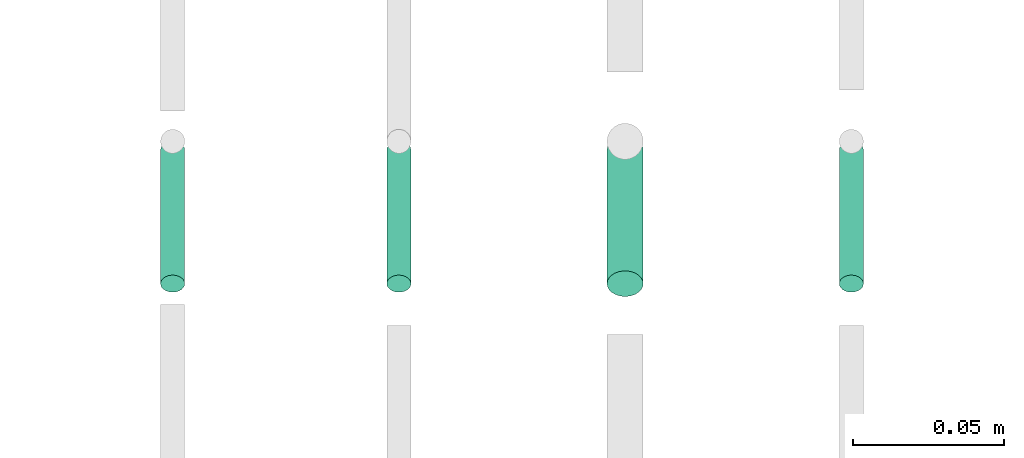
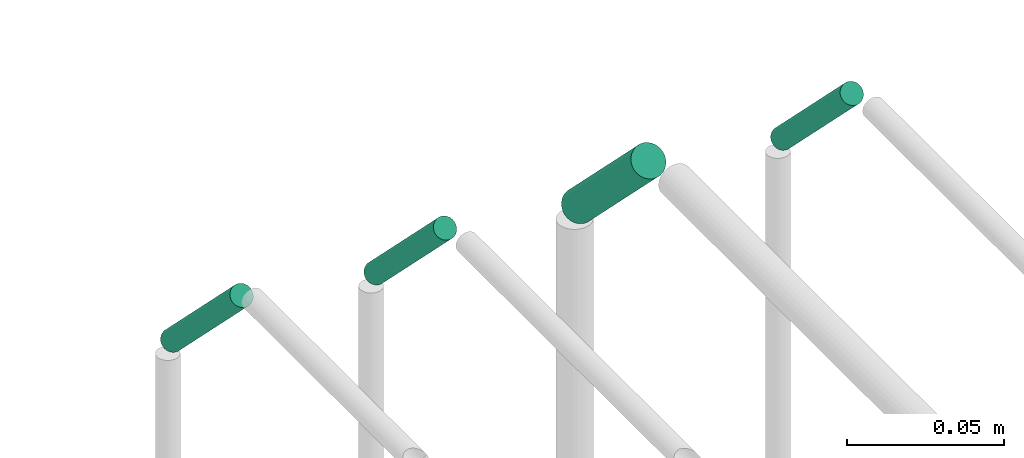
# One storey, part 268 of 331: 4 flow segments.
"""IFC2X3 building model written with IfcOpenShell, lengths in millimetres."""

from ifc_helpers import new_model, entity, si_unit, converted_unit, derived_unit, direction, frame, frame_2d, origin, place, context, subcontext, project, spatial, circle, extrude, type_object, element, save


model = new_model("IFC2X3")

# Units and contexts
model_context = context("Model", 3, precision=0.01, world=origin(), true_north=direction((6.12303176911189e-17, 1.0)))
body_context = subcontext(model_context, "Body", "Model", "MODEL_VIEW")
ifc_project = project(units=[si_unit("LENGTHUNIT", "METRE", prefix="MILLI"), si_unit("AREAUNIT", "SQUARE_METRE"), si_unit("VOLUMEUNIT", "CUBIC_METRE"), converted_unit("PLANEANGLEUNIT", "DEGREE", entity("IfcRatioMeasure", 0.0174532925199433), si_unit("PLANEANGLEUNIT", "RADIAN"), dimensions=[0, 0, 0, 0, 0, 0, 0]), si_unit("MASSUNIT", "GRAM", prefix="KILO"), derived_unit("MASSDENSITYUNIT", [(si_unit("MASSUNIT", "GRAM", prefix="KILO"), 1), (si_unit("LENGTHUNIT", "METRE"), -3)]), derived_unit("MOMENTOFINERTIAUNIT", [(si_unit("LENGTHUNIT", "METRE"), 4)]), si_unit("TIMEUNIT", "SECOND"), si_unit("FREQUENCYUNIT", "HERTZ"), si_unit("THERMODYNAMICTEMPERATUREUNIT", "DEGREE_CELSIUS"), derived_unit("THERMALTRANSMITTANCEUNIT", [(si_unit("MASSUNIT", "GRAM", prefix="KILO"), 1), (si_unit("THERMODYNAMICTEMPERATUREUNIT", "KELVIN"), -1), (si_unit("TIMEUNIT", "SECOND"), -3)]), derived_unit("VOLUMETRICFLOWRATEUNIT", [(si_unit("LENGTHUNIT", "METRE"), 3), (si_unit("TIMEUNIT", "SECOND"), -1)]), derived_unit("MASSFLOWRATEUNIT", [(si_unit("MASSUNIT", "GRAM", prefix="KILO"), 1), (si_unit("TIMEUNIT", "SECOND"), -1)]), derived_unit("ROTATIONALFREQUENCYUNIT", [(si_unit("TIMEUNIT", "SECOND"), -1)]), si_unit("ELECTRICCURRENTUNIT", "AMPERE"), si_unit("ELECTRICVOLTAGEUNIT", "VOLT"), si_unit("POWERUNIT", "WATT"), si_unit("FORCEUNIT", "NEWTON", prefix="KILO"), si_unit("ILLUMINANCEUNIT", "LUX"), si_unit("LUMINOUSFLUXUNIT", "LUMEN"), si_unit("LUMINOUSINTENSITYUNIT", "CANDELA"), derived_unit("USERDEFINED", [(si_unit("MASSUNIT", "GRAM", prefix="KILO"), -1), (si_unit("LENGTHUNIT", "METRE"), -2), (si_unit("TIMEUNIT", "SECOND"), 3), (si_unit("LUMINOUSFLUXUNIT", "LUMEN"), 1)]), derived_unit("LINEARVELOCITYUNIT", [(si_unit("LENGTHUNIT", "METRE"), 1), (si_unit("TIMEUNIT", "SECOND"), -1)]), si_unit("PRESSUREUNIT", "PASCAL"), derived_unit("USERDEFINED", [(si_unit("LENGTHUNIT", "METRE"), -2), (si_unit("MASSUNIT", "GRAM", prefix="KILO"), 1), (si_unit("TIMEUNIT", "SECOND"), -2)]), derived_unit("LINEARFORCEUNIT", [(si_unit("MASSUNIT", "GRAM", prefix="KILO"), 1), (si_unit("LENGTHUNIT", "METRE"), 1), (si_unit("TIMEUNIT", "SECOND"), -2), (si_unit("LENGTHUNIT", "METRE"), -1)]), derived_unit("PLANARFORCEUNIT", [(si_unit("MASSUNIT", "GRAM", prefix="KILO"), 1), (si_unit("LENGTHUNIT", "METRE"), 1), (si_unit("TIMEUNIT", "SECOND"), -2), (si_unit("LENGTHUNIT", "METRE"), -2)])], contexts=[model_context])

# Site, building, storey
site_placement = place(None, frame((0.0, -0.00077364408347762, 0.0)))
site = spatial("IfcSite", under=ifc_project, at=site_placement, CompositionType="ELEMENT")
building_placement = place(site_placement, origin())
building = spatial("IfcBuilding", under=site, at=building_placement, CompositionType="ELEMENT")
storey_placement = place(building_placement, origin())
storey = spatial("IfcBuildingStorey", under=building, at=storey_placement, CompositionType="ELEMENT", Elevation=0.0)

# Flow segments
pipe_segment_type = type_object("IfcPipeSegmentType", PredefinedType="NOTDEFINED")
flow_segment_1_placement = place(building_placement, frame((40316.4101011924, 13958.405560894, 7198.40472776409)))
element("IfcFlowSegment", 1, at=flow_segment_1_placement, inside=storey, type_object=pipe_segment_type, context=body_context, shape_type="SweptSolid", body=[
    extrude(circle(Radius=4.0, at=frame_2d((0.0, -1.53140538050166e-12), x_axis=(1.0, 0.0))), frame((5.59527223591499, 4.42369936066011, 48.7668451111668), z_axis=(0.0, 0.707106781186617, -0.707106781186479), x_axis=(1.0, 0.0, 0.0)), (0.0, 0.0, 1.0), 62.7106781186566),
])
flow_segment_2_placement = place(storey_placement, frame((40391.4101011924, 13958.405560894, 7198.40472776409)))
element("IfcFlowSegment", 2, at=flow_segment_2_placement, inside=storey, type_object=pipe_segment_type, context=body_context, shape_type="SweptSolid", body=[
    extrude(circle(Radius=4.0, at=frame_2d((0.0, -1.53140538050166e-12), x_axis=(1.0, 0.0))), frame((5.59527223591499, 4.42369936066011, 48.7668451111668), z_axis=(0.0, 0.707106781186617, -0.707106781186479), x_axis=(1.0, 0.0, 0.0)), (0.0, 0.0, 1.0), 62.7106781186566),
])
flow_segment_3_placement = place(storey_placement, frame((40464.4101011924, 13956.9913473316, 7196.99051420172)))
element("IfcFlowSegment", 3, at=flow_segment_3_placement, inside=storey, type_object=pipe_segment_type, context=body_context, shape_type="SweptSolid", body=[
    extrude(circle(Radius=6.0, at=frame_2d((0.0, -1.53140538050166e-12), x_axis=(1.0, 0.0))), frame((7.59527223591454, 50.1810586735497, 5.83791292303547), z_axis=(0.0, -0.707106781186617, 0.707106781186479), x_axis=(1.0, 0.0, 0.0)), (0.0, 0.0, 1.0), 62.7106781186584),
])
flow_segment_4_placement = place(storey_placement, frame((40541.4101011924, 13958.405560894, 7198.40472776409)))
element("IfcFlowSegment", 4, at=flow_segment_4_placement, inside=storey, type_object=pipe_segment_type, context=body_context, shape_type="SweptSolid", body=[
    extrude(circle(Radius=4.0, at=frame_2d((0.0, -1.53140538050166e-12), x_axis=(1.0, 0.0))), frame((5.59527223591499, 4.42369936066011, 48.7668451111668), z_axis=(0.0, 0.707106781186617, -0.707106781186479), x_axis=(1.0, 0.0, 0.0)), (0.0, 0.0, 1.0), 62.7106781186566),
])

save(model, "model.ifc")
